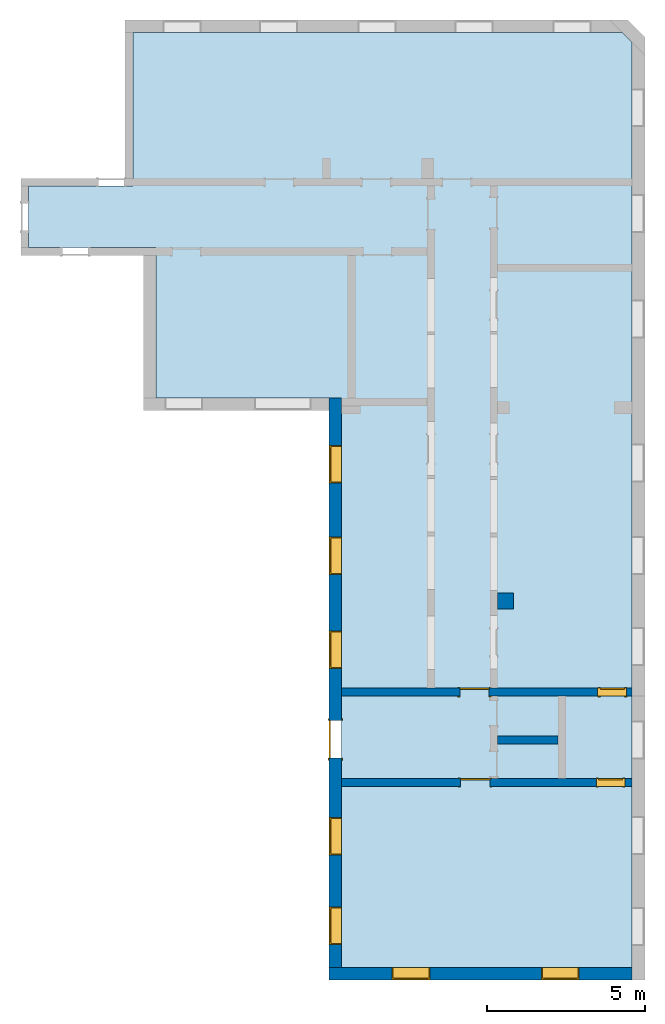
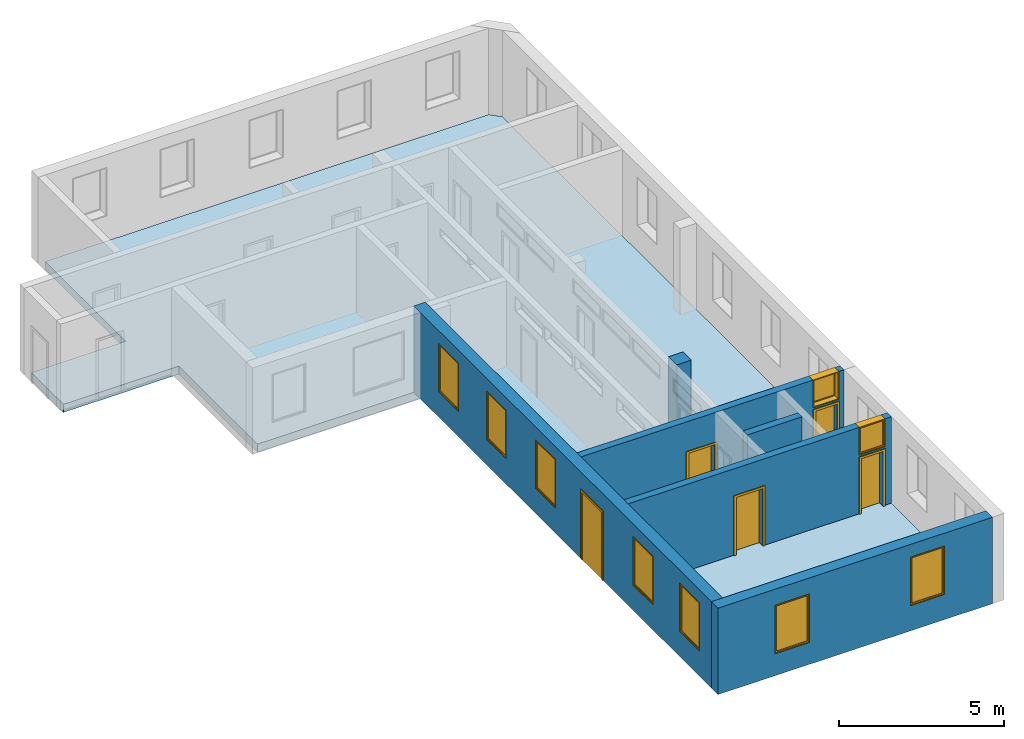
"""IFC2X3 building model written with IfcOpenShell, lengths in millimetres."""

from ifc_helpers import new_model, entity, si_unit, converted_unit, derived_unit, direction, frame, frame_2d, origin, origin_2d_with_axis, place, context, subcontext, project, spatial, polyline, rectangle, outline, extrude, source, transform, mapped, material, material_list, layer, layer_set, layer_usage, type_object, type_shapes, element, fill, save


model = new_model("IFC2X3")

# Units and contexts
model_context = context("Model", 3, precision=0.01, world=origin(), true_north=direction((6.12303176911189e-17, 1.0)))
context_of_model = context(None, 3, precision=0.01, world=origin(), true_north=direction((6.12303176911189e-17, 1.0)))
body_context = subcontext(model_context, "Body", "Model", "MODEL_VIEW")
ifc_project = project(units=[si_unit("LENGTHUNIT", "METRE", prefix="MILLI"), si_unit("AREAUNIT", "SQUARE_METRE"), si_unit("VOLUMEUNIT", "CUBIC_METRE"), converted_unit("PLANEANGLEUNIT", "DEGREE", entity("IfcRatioMeasure", 0.0174532925199433), si_unit("PLANEANGLEUNIT", "RADIAN"), dimensions=[0, 0, 0, 0, 0, 0, 0]), si_unit("MASSUNIT", "GRAM", prefix="KILO"), si_unit("TIMEUNIT", "SECOND"), si_unit("FREQUENCYUNIT", "HERTZ"), si_unit("THERMODYNAMICTEMPERATUREUNIT", "DEGREE_CELSIUS"), derived_unit("THERMALTRANSMITTANCEUNIT", [(si_unit("MASSUNIT", "GRAM", prefix="KILO"), 1), (si_unit("THERMODYNAMICTEMPERATUREUNIT", "KELVIN"), -1), (si_unit("TIMEUNIT", "SECOND"), -3)]), derived_unit("VOLUMETRICFLOWRATEUNIT", [(si_unit("LENGTHUNIT", "METRE"), 3), (si_unit("TIMEUNIT", "SECOND"), -1)]), si_unit("ELECTRICCURRENTUNIT", "AMPERE"), si_unit("ELECTRICVOLTAGEUNIT", "VOLT"), si_unit("POWERUNIT", "WATT"), si_unit("FORCEUNIT", "NEWTON", prefix="KILO"), si_unit("ILLUMINANCEUNIT", "LUX"), si_unit("LUMINOUSFLUXUNIT", "LUMEN"), si_unit("LUMINOUSINTENSITYUNIT", "CANDELA"), si_unit("PRESSUREUNIT", "PASCAL")], contexts=[model_context, context_of_model])

# Site, building, storey
site_placement = place(None, origin())
site = spatial("IfcSite", under=ifc_project, at=site_placement, CompositionType="ELEMENT")
building_placement = place(site_placement, origin())
building = spatial("IfcBuilding", under=site, at=building_placement, CompositionType="ELEMENT")
storey_1_placement = place(building_placement, origin())
storey_1 = spatial("IfcBuildingStorey", under=building, at=storey_1_placement, Name="i Plan", CompositionType="ELEMENT", Elevation=-5.41433564649196e-13)

# Slab
ifc_material_1 = material(Name="Default Floor")
ifc_layer_1 = layer(ifc_material_1, 300.0)
ifc_layer_set_1 = layer_set([ifc_layer_1], Name="Floor:Generic 300mm")
ifc_layer_usage_1 = layer_usage(ifc_layer_set_1, "AXIS3", "POSITIVE", 0.0)
slab_placement = place(storey_1_placement, origin())
element("IfcSlab", 1, at=slab_placement, inside=storey_1, material=ifc_layer_usage_1, Name="Floor:Generic 300mm", ObjectType="Floor:Generic 300mm", PredefinedType="FLOOR", context=body_context, shape_type="SweptSolid", body=[
    extrude(outline(polyline([(2827.55145361487, -8327.16929691403), (4776.72462534005, -8327.16929691403), (4776.72462534005, -5027.66312908422), (9646.31107922707, -5027.66312908421), (9646.31107922703, 10500.4665578726), (9343.94693401368, 10802.830703086), (-19985.4923423081, 10802.830703086), (-19985.4923423081, 1589.20257319905), (-1937.06828288073, 1589.20257319903), (-1937.06828288071, -4287.4341292231), (2827.55145361486, -4287.4341292231), (2827.55145361487, -8327.16929691403)])), frame((-5700.79066597761, 4570.08411792073, 0.0), z_axis=(0.0, 0.0, -1.0), x_axis=(0.0, 1.0, 0.0)), (0.0, 0.0, 1.0), 300.0),
])

# Wall, openings
ifc_material_2 = material(Name="Brick, Common")
ifc_layer_2 = layer(ifc_material_2, 400.0)
ifc_layer_set_2 = layer_set([ifc_layer_2], Name="Basic Wall:400mm")
ifc_layer_usage_2 = layer_usage(ifc_layer_set_2, "AXIS2", "NEGATIVE", 200.0)
wall_type_1 = type_object("IfcWallType", Name="Basic Wall:400mm", PredefinedType="STANDARD", material=ifc_layer_set_2)
wall_1_placement = place(storey_1_placement, frame((5102.04003710832, -15615.4082243874, 0.0), z_axis=(0.0, 0.0, 1.0), x_axis=(-1.0, 0.0, 0.0)))
wall_1 = element("IfcWallStandardCase", 2, at=wall_1_placement, inside=storey_1, type_object=wall_type_1, material=ifc_layer_usage_2, Name="Basic Wall:400mm", ObjectType="Basic Wall:400mm", context=body_context, shape_type="SweptSolid", body=[
    extrude(rectangle(XDim=9613.62812988691, YDim=400.0, at=frame_2d((4806.81406494345, 5.11590769747272e-13), x_axis=(-1.0, 0.0))), origin(), (0.0, 0.0, 1.0), 3199.99999999984),
])
opening_1_placement = place(wall_1_placement, frame((1680.0, -200.0, 930.0)))
opening_1 = element("IfcOpeningElement", 3, at=opening_1_placement, cuts=wall_1, Name="M_Fixed:72_1", ObjectType="Opening", context=body_context, shape_type="SweptSolid", body=[
    extrude(rectangle(XDim=1800.0, YDim=1200.0, at=frame_2d((899.999999999998, 600.0), x_axis=(1.0, 0.0))), frame((0.0, 0.0, 0.0), z_axis=(0.0, 1.0, 0.0), x_axis=(0.0, 0.0, 1.0)), (0.0, 0.0, 1.0), 400.0),
])
opening_2_placement = place(wall_1_placement, frame((6413.6281298869, -200.0, 810.0)))
opening_2 = element("IfcOpeningElement", 4, at=opening_2_placement, cuts=wall_1, Name="M_Fixed:72_1", ObjectType="Opening", context=body_context, shape_type="SweptSolid", body=[
    extrude(rectangle(XDim=1800.0, YDim=1200.0, at=frame_2d((899.999999999998, 600.0), x_axis=(1.0, 0.0))), frame((0.0, 0.0, 0.0), z_axis=(0.0, 1.0, 0.0), x_axis=(0.0, 0.0, 1.0)), (0.0, 0.0, 1.0), 400.0),
])

# Storey
storey_2_placement = place(building_placement, frame((0.0, 0.0, 960.0)))
storey_2 = spatial("IfcBuildingStorey", under=building, at=storey_2_placement, Name="Bottom windows", CompositionType="ELEMENT", Elevation=959.999999999999)

# Window
ifc_material_3 = material(Name="Glass")
ifc_material_4 = material(Name="Sash")
ifc_material_list_1 = material_list([ifc_material_3, ifc_material_4])
ifc_material_list_2 = material_list([ifc_material_3, ifc_material_4])
window_style_1 = type_object("IfcWindowStyle", Name="72", ConstructionType="NOTDEFINED", OperationType="NOTDEFINED", ParameterTakesPrecedence=False, Sizeable=False, material=ifc_material_list_2)
shared_shape_1 = source(origin(), body_context, "Body", "SweptSolid", [
    extrude(rectangle(XDim=12.0, YDim=1074.0, at=origin_2d_with_axis()), frame((600.0, 359.0, 63.0), z_axis=(0.0, 0.0, 1.0), x_axis=(0.0, -1.0, 0.0)), (0.0, 0.0, 1.0), 1674.0),
    extrude(outline(polyline([(-581.0, -881.0), (581.0, -881.0), (581.0, 881.0), (-581.0, 881.0), (-581.0, -881.0)]), holes=[polyline([(-537.0, -837.0), (-537.0, 837.0), (537.0, 837.0), (537.0, -837.0), (-537.0, -837.0)])]), frame((600.0, 337.0, 900.0), z_axis=(0.0, 1.0, 0.0), x_axis=(1.0, 0.0, 0.0)), (0.0, 0.0, 1.0), 44.0000000000274),
    extrude(outline(polyline([(-600.0, -900.0), (600.0, -900.0), (600.0, 900.0), (-600.0, 900.0), (-600.0, -900.0)]), holes=[polyline([(-581.0, -881.0), (-581.0, 881.0), (581.0, 881.0), (581.0, -881.0), (-581.0, -881.0)])]), frame((600.0, 337.0, 900.0), z_axis=(0.0, 1.0, 0.0), x_axis=(1.0, 0.0, 0.0)), (0.0, 0.0, 1.0), 63.0000000000275),
    extrude(outline(polyline([(-600.0, -900.0), (600.0, -900.0), (600.0, 900.0), (-600.0, 900.0), (-600.0, -900.0)]), holes=[polyline([(-568.0, -868.0), (-568.0, 868.0), (568.0, 868.0), (568.0, -868.0), (-568.0, -868.0)])]), frame((600.0, 0.0, 900.0), z_axis=(0.0, 1.0, 0.0), x_axis=(1.0, 0.0, 0.0)), (0.0, 0.0, 1.0), 336.999999999973),
])
type_shapes(window_style_1, [shared_shape_1])
window_1_placement = place(opening_1_placement, origin())
window_1 = element("IfcWindow", 5, at=window_1_placement, inside=storey_2, type_object=window_style_1, material=ifc_material_list_1, Name="M_Fixed:72", ObjectType="72", OverallHeight=1800.0, OverallWidth=1200.0, context=body_context, shape_type="MappedRepresentation", body=[
    mapped(shared_shape_1, transform((0.0, 0.0, 0.0), scale=1.0)),
])

fill(opening_1, window_1)

ifc_material_list_3 = material_list([ifc_material_3, ifc_material_4])
window_2_placement = place(opening_2_placement, origin())
window_2 = element("IfcWindow", 6, at=window_2_placement, inside=storey_1, type_object=window_style_1, material=ifc_material_list_3, Name="M_Fixed:72", ObjectType="72", OverallHeight=1800.0, OverallWidth=1200.0, context=body_context, shape_type="MappedRepresentation", body=[
    mapped(shared_shape_1, transform((0.0, 0.0, 0.0), scale=1.0)),
])

fill(opening_2, window_2)

# Wall, openings, windows, door
ifc_layer_usage_3 = layer_usage(ifc_layer_set_2, "AXIS2", "NEGATIVE", 200.0)
wall_2_placement = place(storey_1_placement, frame((-4311.58809277858, -15415.4082243873, 0.0), z_axis=(0.0, 0.0, 1.0), x_axis=(0.0, 1.0, 0.0)))
wall_2 = element("IfcWallStandardCase", 7, at=wall_2_placement, inside=storey_1, type_object=wall_type_1, material=ifc_layer_usage_3, Name="Basic Wall:400mm", ObjectType="Basic Wall:400mm", context=body_context, shape_type="SweptSolid", body=[
    extrude(rectangle(XDim=18048.4240594273, YDim=400.0, at=frame_2d((9024.21202971367, 0.0), x_axis=(-1.0, 0.0))), origin(), (0.0, 0.0, 1.0), 3199.99999999984),
])
opening_3_placement = place(wall_2_placement, frame((6631.21794312934, -200.0, 0.0)))
opening_3 = element("IfcOpeningElement", 8, at=opening_3_placement, cuts=wall_2, Name="M_Single-Flush:Great Door:1", ObjectType="Opening", context=body_context, shape_type="SweptSolid", body=[
    extrude(rectangle(XDim=1190.0, YDim=2500.0, at=frame_2d((1250.0, 595.0), x_axis=(0.0, -1.0))), frame((0.0, 0.0, 0.0), z_axis=(0.0, 1.0, 0.0), x_axis=(0.0, 0.0, 1.0)), (0.0, 0.0, 1.0), 400.0),
])
opening_4_placement = place(wall_2_placement, frame((15348.4240594273, -200.0, 930.0)))
opening_4 = element("IfcOpeningElement", 9, at=opening_4_placement, cuts=wall_2, Name="M_Fixed:72_1", ObjectType="Opening", context=body_context, shape_type="SweptSolid", body=[
    extrude(rectangle(XDim=1800.0, YDim=1200.0, at=frame_2d((899.999999999998, 600.0), x_axis=(1.0, 0.0))), frame((0.0, 0.0, 0.0), z_axis=(0.0, 1.0, 0.0), x_axis=(0.0, 0.0, 1.0)), (0.0, 0.0, 1.0), 400.0),
])
opening_5_placement = place(wall_2_placement, frame((12448.4240594273, -200.0, 930.0)))
opening_5 = element("IfcOpeningElement", 10, at=opening_5_placement, cuts=wall_2, Name="M_Fixed:72_1", ObjectType="Opening", context=body_context, shape_type="SweptSolid", body=[
    extrude(rectangle(XDim=1800.0, YDim=1200.0, at=frame_2d((899.999999999998, 600.0), x_axis=(1.0, 0.0))), frame((0.0, 0.0, 0.0), z_axis=(0.0, 1.0, 0.0), x_axis=(0.0, 0.0, 1.0)), (0.0, 0.0, 1.0), 400.0),
])
opening_6_placement = place(wall_2_placement, frame((9468.42405942734, -200.0, 930.0)))
opening_6 = element("IfcOpeningElement", 11, at=opening_6_placement, cuts=wall_2, Name="M_Fixed:72_1", ObjectType="Opening", context=body_context, shape_type="SweptSolid", body=[
    extrude(rectangle(XDim=1800.0, YDim=1200.0, at=frame_2d((899.999999999998, 600.0), x_axis=(1.0, 0.0))), frame((0.0, 0.0, 0.0), z_axis=(0.0, 1.0, 0.0), x_axis=(0.0, 0.0, 1.0)), (0.0, 0.0, 1.0), 400.0),
])
opening_7_placement = place(wall_2_placement, frame((3556.21794312935, -200.0, 930.0)))
opening_7 = element("IfcOpeningElement", 12, at=opening_7_placement, cuts=wall_2, Name="M_Fixed:72_1", ObjectType="Opening", context=body_context, shape_type="SweptSolid", body=[
    extrude(rectangle(XDim=1800.0, YDim=1200.0, at=frame_2d((899.999999999998, 600.0), x_axis=(1.0, 0.0))), frame((0.0, 0.0, 0.0), z_axis=(0.0, 1.0, 0.0), x_axis=(0.0, 0.0, 1.0)), (0.0, 0.0, 1.0), 400.0),
])
opening_8_placement = place(wall_2_placement, frame((720.0, -200.0, 930.0)))
opening_8 = element("IfcOpeningElement", 13, at=opening_8_placement, cuts=wall_2, Name="M_Fixed:72_1", ObjectType="Opening", context=body_context, shape_type="SweptSolid", body=[
    extrude(rectangle(XDim=1800.0, YDim=1200.0, at=frame_2d((899.999999999998, 600.0), x_axis=(1.0, 0.0))), frame((0.0, 0.0, 0.0), z_axis=(0.0, 1.0, 0.0), x_axis=(0.0, 0.0, 1.0)), (0.0, 0.0, 1.0), 400.0),
])
ifc_material_list_4 = material_list([ifc_material_3, ifc_material_4])
window_3_placement = place(opening_4_placement, origin())
window_3 = element("IfcWindow", 14, at=window_3_placement, inside=storey_2, type_object=window_style_1, material=ifc_material_list_4, Name="M_Fixed:72", ObjectType="72", OverallHeight=1800.0, OverallWidth=1200.0, context=body_context, shape_type="MappedRepresentation", body=[
    mapped(shared_shape_1, transform((0.0, 0.0, 0.0), scale=1.0)),
])
fill(opening_4, window_3)
ifc_material_list_5 = material_list([ifc_material_3, ifc_material_4])
window_4_placement = place(opening_5_placement, origin())
window_4 = element("IfcWindow", 15, at=window_4_placement, inside=storey_2, type_object=window_style_1, material=ifc_material_list_5, Name="M_Fixed:72", ObjectType="72", OverallHeight=1800.0, OverallWidth=1200.0, context=body_context, shape_type="MappedRepresentation", body=[
    mapped(shared_shape_1, transform((0.0, 0.0, 0.0), scale=1.0)),
])
fill(opening_5, window_4)
ifc_material_list_6 = material_list([ifc_material_3, ifc_material_4])
window_5_placement = place(opening_6_placement, origin())
window_5 = element("IfcWindow", 16, at=window_5_placement, inside=storey_2, type_object=window_style_1, material=ifc_material_list_6, Name="M_Fixed:72", ObjectType="72", OverallHeight=1800.0, OverallWidth=1200.0, context=body_context, shape_type="MappedRepresentation", body=[
    mapped(shared_shape_1, transform((0.0, 0.0, 0.0), scale=1.0)),
])
fill(opening_6, window_5)
ifc_material_list_7 = material_list([ifc_material_3, ifc_material_4])
window_6_placement = place(opening_7_placement, origin())
window_6 = element("IfcWindow", 17, at=window_6_placement, inside=storey_2, type_object=window_style_1, material=ifc_material_list_7, Name="M_Fixed:72", ObjectType="72", OverallHeight=1800.0, OverallWidth=1200.0, context=body_context, shape_type="MappedRepresentation", body=[
    mapped(shared_shape_1, transform((0.0, 0.0, 0.0), scale=1.0)),
])
fill(opening_7, window_6)
ifc_material_list_8 = material_list([ifc_material_3, ifc_material_4])
window_7_placement = place(opening_8_placement, origin())
window_7 = element("IfcWindow", 18, at=window_7_placement, inside=storey_2, type_object=window_style_1, material=ifc_material_list_8, Name="M_Fixed:72", ObjectType="72", OverallHeight=1800.0, OverallWidth=1200.0, context=body_context, shape_type="MappedRepresentation", body=[
    mapped(shared_shape_1, transform((0.0, 0.0, 0.0), scale=1.0)),
])
fill(opening_8, window_7)
ifc_material_5 = material(Name="Door - Frame")
ifc_material_6 = material(Name="Door - Panel")
ifc_material_list_9 = material_list([ifc_material_5, ifc_material_6])
ifc_material_list_10 = material_list([ifc_material_5, ifc_material_6])
door_style_1 = type_object("IfcDoorStyle", Name="Great Door", ConstructionType="NOTDEFINED", OperationType="SINGLE_SWING_LEFT", ParameterTakesPrecedence=False, Sizeable=False, material=ifc_material_list_10)
shared_shape_2 = source(origin(), body_context, "Body", "SweptSolid", [
    extrude(outline(polyline([(-671.0, -1307.0), (671.0, -1307.0), (671.0, 1269.0), (595.0, 1269.0), (595.0, -1231.0), (-595.0, -1231.0), (-595.0, 1269.0), (-671.0, 1269.0), (-671.0, -1307.0)])), frame((595.0, 425.0, 1269.0), z_axis=(0.0, -1.0, 0.0), x_axis=(-1.0, 0.0, 0.0)), (0.0, 0.0, 1.0), 24.9999999999945),
    extrude(outline(polyline([(-1307.0, -671.0), (1269.0, -671.0), (1269.0, -595.0), (-1231.0, -595.0), (-1231.0, 595.0), (1269.0, 595.0), (1269.0, 671.0), (-1307.0, 671.0), (-1307.0, -671.0)])), frame((595.0, 0.0, 1269.0), z_axis=(0.0, -1.0, 0.0), x_axis=(0.0, 0.0, -1.0)), (0.0, 0.0, 1.0), 25.0000000000056),
    extrude(rectangle(XDim=1190.0, YDim=51.0, at=frame_2d((0.0, 1.77635683940025e-14), x_axis=(1.0, 0.0))), frame((595.0, 374.499999999994, 0.0)), (0.0, 0.0, 1.0), 2500.0),
])
type_shapes(door_style_1, [shared_shape_2])
door_1_placement = place(opening_3_placement, origin())
door_1 = element("IfcDoor", 19, at=door_1_placement, inside=storey_1, type_object=door_style_1, material=ifc_material_list_9, Name="M_Single-Flush:Great Door", ObjectType="Great Door", OverallHeight=2500.0, OverallWidth=1190.0, context=body_context, shape_type="MappedRepresentation", body=[
    mapped(shared_shape_2, transform((0.0, 0.0, 0.0), scale=1.0)),
])
fill(opening_3, door_1)

# Wall, openings, doors, window
ifc_material_7 = material(Name="Default Wall")
ifc_layer_3 = layer(ifc_material_7, 250.0)
ifc_layer_set_3 = layer_set([ifc_layer_3], Name="Basic Wall:250 mm")
ifc_layer_usage_4 = layer_usage(ifc_layer_set_3, "AXIS2", "NEGATIVE", 125.0)
wall_type_2 = type_object("IfcWallType", Name="Basic Wall:250 mm", PredefinedType="STANDARD", material=ifc_layer_set_3)
wall_3_placement = place(storey_1_placement, frame((5102.04003710834, -6688.09629601622, 0.0), z_axis=(0.0, 0.0, 1.0), x_axis=(-1.0, 0.0, 0.0)))
wall_3 = element("IfcWallStandardCase", 20, at=wall_3_placement, inside=storey_1, type_object=wall_type_2, material=ifc_layer_usage_4, Name="Basic Wall:250 mm", ObjectType="Basic Wall:250 mm", context=body_context, shape_type="SweptSolid", body=[
    extrude(rectangle(XDim=9213.62812988691, YDim=249.999999999999, at=frame_2d((4606.81406494345, -2.77111666946439e-13), x_axis=(-1.0, 0.0))), origin(), (0.0, 0.0, 1.0), 3200.0),
])
opening_9_placement = place(wall_3_placement, frame((5453.6281298869, 125.0, 0.0)))
opening_9 = element("IfcOpeningElement", 21, at=opening_9_placement, cuts=wall_3, Name="M_Single-Flush:0915 x 2032mm:1", ObjectType="Opening", context=body_context, shape_type="SweptSolid", body=[
    extrude(rectangle(XDim=915.0, YDim=2032.0, at=frame_2d((1016.0, 457.5), x_axis=(0.0, 1.0))), frame((0.0, 0.0, 0.0), z_axis=(0.0, -1.0, 0.0), x_axis=(0.0, 0.0, 1.0)), (0.0, 0.0, 1.0), 250.0),
])
opening_10_placement = place(wall_3_placement, frame((1007.0, 125.0, 0.0)))
opening_10 = element("IfcOpeningElement", 22, at=opening_10_placement, cuts=wall_3, Name="M_Single-Flush:0762 x 2032mm:1", ObjectType="Opening", context=body_context, shape_type="SweptSolid", body=[
    extrude(rectangle(XDim=762.0, YDim=2032.0, at=frame_2d((1016.0, 381.0), x_axis=(0.0, 1.0))), frame((0.0, 0.0, 0.0), z_axis=(0.0, -1.0, 0.0), x_axis=(0.0, 0.0, 1.0)), (0.0, 0.0, 1.0), 250.0),
])
opening_11_placement = place(wall_3_placement, frame((1094.0, 125.0, 2172.0)))
opening_11 = element("IfcOpeningElement", 23, at=opening_11_placement, cuts=wall_3, Name="M_Fixed:762:1", ObjectType="Opening", context=body_context, shape_type="SweptSolid", body=[
    extrude(rectangle(XDim=1028.0, YDim=914.0, at=frame_2d((513.999999999999, 457.0), x_axis=(1.0, 0.0))), frame((0.0, 0.0, 0.0), z_axis=(0.0, -1.0, 0.0), x_axis=(0.0, 0.0, 1.0)), (0.0, 0.0, 1.0), 250.0),
])
ifc_material_list_11 = material_list([ifc_material_5, ifc_material_6])
ifc_material_list_12 = material_list([ifc_material_5, ifc_material_6])
door_style_2 = type_object("IfcDoorStyle", Name="0762 x 2032mm", ConstructionType="NOTDEFINED", OperationType="SINGLE_SWING_RIGHT", ParameterTakesPrecedence=False, Sizeable=False, material=ifc_material_list_12)
shared_shape_3 = source(origin(), body_context, "Body", "SweptSolid", [
    extrude(outline(polyline([(-457.0, -1073.0), (457.0, -1073.0), (457.0, 1035.0), (381.0, 1035.0), (381.0, -997.0), (-381.0, -997.0), (-381.0, 1035.0), (-457.0, 1035.0), (-457.0, -1073.0)])), frame((381.0, 250.0, 1035.0), z_axis=(0.0, 1.0, 0.0), x_axis=(1.0, 0.0, 0.0)), (0.0, 0.0, 1.0), 24.9999999999945),
    extrude(outline(polyline([(-1073.0, -457.0), (1035.0, -457.0), (1035.0, -381.0), (-997.0, -381.0), (-997.0, 381.0), (1035.0, 381.0), (1035.0, 457.0), (-1073.0, 457.0), (-1073.0, -457.0)])), frame((381.0, -25.0, 1035.0), z_axis=(0.0, 1.0, 0.0), x_axis=(0.0, 0.0, -1.0)), (0.0, 0.0, 1.0), 25.0000000000056),
    extrude(rectangle(XDim=51.0, YDim=762.0, at=frame_2d((5.32907051820075e-15, 0.0), x_axis=(1.0, 0.0))), frame((381.0, 224.499999999999, 0.0), z_axis=(0.0, 0.0, 1.0), x_axis=(0.0, 1.0, 0.0)), (0.0, 0.0, 1.0), 2032.0),
])
type_shapes(door_style_2, [shared_shape_3])
door_2_placement = place(opening_10_placement, frame((0.0, 0.0, 0.0), z_axis=(0.0, 0.0, 1.0), x_axis=(-1.0, 0.0, 0.0)))
door_2 = element("IfcDoor", 24, at=door_2_placement, inside=storey_1, type_object=door_style_2, material=ifc_material_list_11, Name="M_Single-Flush:0762 x 2032mm", ObjectType="0762 x 2032mm", OverallHeight=2032.0, OverallWidth=762.0, context=body_context, shape_type="MappedRepresentation", body=[
    mapped(shared_shape_3, transform((0.0, 0.0, 0.0), scale=1.0)),
])
fill(opening_10, door_2)
ifc_material_list_13 = material_list([ifc_material_5, ifc_material_6])
ifc_material_list_14 = material_list([ifc_material_5, ifc_material_6])
door_style_3 = type_object("IfcDoorStyle", Name="0915 x 2032mm", ConstructionType="NOTDEFINED", OperationType="SINGLE_SWING_RIGHT", ParameterTakesPrecedence=False, Sizeable=False, material=ifc_material_list_14)
shared_shape_4 = source(origin(), body_context, "Body", "SweptSolid", [
    extrude(outline(polyline([(-533.5, -1073.0), (533.5, -1073.0), (533.5, 1035.0), (457.5, 1035.0), (457.5, -997.0), (-457.5, -997.0), (-457.5, 1035.0), (-533.5, 1035.0), (-533.5, -1073.0)])), frame((457.5, 250.0, 1035.0), z_axis=(0.0, 1.0, 0.0), x_axis=(1.0, 0.0, 0.0)), (0.0, 0.0, 1.0), 24.9999999999945),
    extrude(outline(polyline([(-1073.0, -533.499999999997), (1035.0, -533.499999999997), (1035.0, -457.500000000007), (-997.0, -457.500000000007), (-997.0, 457.500000000002), (1035.0, 457.500000000002), (1035.0, 533.500000000003), (-1073.0, 533.500000000003), (-1073.0, -533.499999999997)])), frame((457.500000000003, -25.0, 1035.0), z_axis=(0.0, 1.0, 0.0), x_axis=(0.0, 0.0, -1.0)), (0.0, 0.0, 1.0), 25.0000000000056),
    extrude(rectangle(XDim=51.0, YDim=915.0, at=frame_2d((5.32907051820075e-15, 0.0), x_axis=(1.0, 0.0))), frame((457.5, 224.500000000001, 0.0), z_axis=(0.0, 0.0, 1.0), x_axis=(0.0, 1.0, 0.0)), (0.0, 0.0, 1.0), 2032.0),
])
type_shapes(door_style_3, [shared_shape_4])
door_3_placement = place(opening_9_placement, frame((0.0, 0.0, 0.0), z_axis=(0.0, 0.0, 1.0), x_axis=(-1.0, 0.0, 0.0)))
door_3 = element("IfcDoor", 25, at=door_3_placement, inside=storey_1, type_object=door_style_3, material=ifc_material_list_13, Name="M_Single-Flush:0915 x 2032mm", ObjectType="0915 x 2032mm", OverallHeight=2032.0, OverallWidth=915.0, context=body_context, shape_type="MappedRepresentation", body=[
    mapped(shared_shape_4, transform((0.0, 0.0, 0.0), scale=1.0)),
])
fill(opening_9, door_3)
ifc_material_list_15 = material_list([ifc_material_3, ifc_material_4])
ifc_material_list_16 = material_list([ifc_material_3, ifc_material_4])
window_style_2 = type_object("IfcWindowStyle", Name="762", ConstructionType="NOTDEFINED", OperationType="NOTDEFINED", ParameterTakesPrecedence=False, Sizeable=False, material=ifc_material_list_16)
shared_shape_5 = source(origin(), body_context, "Body", "SweptSolid", [
    extrude(rectangle(XDim=12.0, YDim=787.999999999997, at=frame_2d((-8.43769498715119e-15, 0.0), x_axis=(1.0, 0.0))), frame((457.0, 209.0, 63.0), z_axis=(0.0, 0.0, 1.0), x_axis=(0.0, -1.0, 0.0)), (0.0, 0.0, 1.0), 902.000000000008),
    extrude(outline(polyline([(-438.0, -495.0), (438.0, -495.0), (438.0, 495.0), (-438.0, 495.0), (-438.0, -495.0)]), holes=[polyline([(-394.0, -451.0), (-394.0, 451.0), (394.0, 451.0), (394.0, -451.0), (-394.0, -451.0)])]), frame((457.0, 187.0, 514.0), z_axis=(0.0, 1.0, 0.0), x_axis=(1.0, 0.0, 0.0)), (0.0, 0.0, 1.0), 44.0000000000274),
    extrude(outline(polyline([(-457.0, -514.0), (457.0, -514.0), (457.0, 514.0), (-457.0, 514.0), (-457.0, -514.0)]), holes=[polyline([(-438.0, -495.0), (-438.0, 495.0), (438.0, 495.0), (438.0, -495.0), (-438.0, -495.0)])]), frame((457.0, 187.0, 514.0), z_axis=(0.0, 1.0, 0.0), x_axis=(1.0, 0.0, 0.0)), (0.0, 0.0, 1.0), 63.0000000000274),
    extrude(outline(polyline([(-457.0, -514.0), (457.0, -514.0), (457.0, 514.0), (-457.0, 514.0), (-457.0, -514.0)]), holes=[polyline([(-425.0, -482.0), (-425.0, 482.0), (425.0, 482.0), (425.0, -482.0), (-425.0, -482.0)])]), frame((457.0, 0.0, 514.0), z_axis=(0.0, 1.0, 0.0), x_axis=(1.0, 0.0, 0.0)), (0.0, 0.0, 1.0), 186.999999999973),
])
type_shapes(window_style_2, [shared_shape_5])
window_8_placement = place(opening_11_placement, frame((0.0, 0.0, 0.0), z_axis=(0.0, 0.0, 1.0), x_axis=(-1.0, 0.0, 0.0)))
window_8 = element("IfcWindow", 26, at=window_8_placement, inside=storey_2, type_object=window_style_2, material=ifc_material_list_15, Name="M_Fixed:762", ObjectType="762", OverallHeight=1028.0, OverallWidth=914.0, context=body_context, shape_type="MappedRepresentation", body=[
    mapped(shared_shape_5, transform((0.0, 0.0, 0.0), scale=1.0)),
])
fill(opening_11, window_8)

ifc_layer_usage_5 = layer_usage(ifc_layer_set_3, "AXIS2", "NEGATIVE", 125.0)
wall_4_placement = place(storey_1_placement, frame((-4111.58809277857, -9554.19028125798, 0.0)))
wall_4 = element("IfcWallStandardCase", 27, at=wall_4_placement, inside=storey_1, type_object=wall_type_2, material=ifc_layer_usage_5, Name="Basic Wall:250 mm", ObjectType="Basic Wall:250 mm", context=body_context, shape_type="SweptSolid", body=[
    extrude(rectangle(XDim=9213.62812988691, YDim=249.999999999999, at=frame_2d((4606.81406494345, 1.06581410364015e-13), x_axis=(-1.0, 0.0))), origin(), (0.0, 0.0, 1.0), 3200.1),
])
opening_12_placement = place(wall_4_placement, frame((3770.0, -125.0, 0.0)))
opening_12 = element("IfcOpeningElement", 28, at=opening_12_placement, cuts=wall_4, Name="M_Single-Flush:72 door wide:1", ObjectType="Opening", context=body_context, shape_type="SweptSolid", body=[
    extrude(rectangle(XDim=930.0, YDim=2134.0, at=frame_2d((1067.0, 465.0), x_axis=(0.0, 1.0))), frame((0.0, 0.0, 0.0), z_axis=(0.0, 1.0, 0.0), x_axis=(0.0, 0.0, 1.0)), (0.0, 0.0, 1.0), 250.0),
])
opening_13_placement = place(wall_4_placement, frame((8151.6281298869, -125.0, 0.0)))
opening_13 = element("IfcOpeningElement", 29, at=opening_13_placement, cuts=wall_4, Name="M_Single-Flush:0762 x 2032mm:1", ObjectType="Opening", context=body_context, shape_type="SweptSolid", body=[
    extrude(rectangle(XDim=762.0, YDim=2032.0, at=frame_2d((1016.0, 381.0), x_axis=(0.0, 1.0))), frame((0.0, 0.0, 0.0), z_axis=(0.0, 1.0, 0.0), x_axis=(0.0, 0.0, 1.0)), (0.0, 0.0, 1.0), 250.0),
])
opening_14_placement = place(wall_4_placement, frame((8993.62812988687, 125.0, 2172.1)))
opening_14 = element("IfcOpeningElement", 30, at=opening_14_placement, cuts=wall_4, Name="M_Fixed:762:1", ObjectType="Opening", context=body_context, shape_type="SweptSolid", body=[
    extrude(rectangle(XDim=1028.0, YDim=914.0, at=frame_2d((513.999999999999, 457.0), x_axis=(1.0, 0.0))), frame((0.0, 0.0, 0.0), z_axis=(0.0, -1.0, 0.0), x_axis=(0.0, 0.0, 1.0)), (0.0, 0.0, 1.0), 250.0),
])
ifc_material_list_17 = material_list([ifc_material_5, ifc_material_6])
ifc_material_list_18 = material_list([ifc_material_5, ifc_material_6])
door_style_4 = type_object("IfcDoorStyle", Name="72 door wide", ConstructionType="NOTDEFINED", OperationType="SINGLE_SWING_RIGHT", ParameterTakesPrecedence=False, Sizeable=False, material=ifc_material_list_18)
shared_shape_6 = source(origin(), body_context, "Body", "SweptSolid", [
    extrude(outline(polyline([(-541.0, -1124.0), (541.0, -1124.0), (541.0, 1086.0), (465.0, 1086.0), (465.0, -1048.0), (-465.0, -1048.0), (-465.0, 1086.0), (-541.0, 1086.0), (-541.0, -1124.0)])), frame((465.0, 250.0, 1086.0), z_axis=(0.0, 1.0, 0.0), x_axis=(1.0, 0.0, 0.0)), (0.0, 0.0, 1.0), 24.9999999999945),
    extrude(outline(polyline([(-1124.0, -541.0), (1086.0, -541.0), (1086.0, -465.0), (-1048.0, -465.0), (-1048.0, 465.0), (1086.0, 465.0), (1086.0, 541.0), (-1124.0, 541.0), (-1124.0, -541.0)])), frame((465.0, -25.0, 1086.0), z_axis=(0.0, 1.0, 0.0), x_axis=(0.0, 0.0, -1.0)), (0.0, 0.0, 1.0), 25.0000000000056),
    extrude(rectangle(XDim=51.0, YDim=930.0, at=frame_2d((5.32907051820075e-15, 0.0), x_axis=(1.0, 0.0))), frame((465.0, 224.499999999999, 0.0), z_axis=(0.0, 0.0, 1.0), x_axis=(0.0, 1.0, 0.0)), (0.0, 0.0, 1.0), 2134.0),
])
type_shapes(door_style_4, [shared_shape_6])
door_4_placement = place(opening_12_placement, origin())
door_4 = element("IfcDoor", 31, at=door_4_placement, inside=storey_1, type_object=door_style_4, material=ifc_material_list_17, Name="M_Single-Flush:72 door wide", ObjectType="72 door wide", OverallHeight=2134.0, OverallWidth=930.0, context=body_context, shape_type="MappedRepresentation", body=[
    mapped(shared_shape_6, transform((0.0, 0.0, 0.0), scale=1.0)),
])
fill(opening_12, door_4)
ifc_material_list_19 = material_list([ifc_material_5, ifc_material_6])
door_5_placement = place(opening_13_placement, origin())
door_5 = element("IfcDoor", 32, at=door_5_placement, inside=storey_1, type_object=door_style_2, material=ifc_material_list_19, Name="M_Single-Flush:0762 x 2032mm", ObjectType="0762 x 2032mm", OverallHeight=2032.0, OverallWidth=762.0, context=body_context, shape_type="MappedRepresentation", body=[
    mapped(shared_shape_3, transform((0.0, 0.0, 0.0), scale=1.0)),
])
fill(opening_13, door_5)
ifc_material_list_20 = material_list([ifc_material_3, ifc_material_4])
window_9_placement = place(opening_14_placement, frame((0.0, 0.0, 0.0), z_axis=(0.0, 0.0, 1.0), x_axis=(-1.0, 0.0, 0.0)))
window_9 = element("IfcWindow", 33, at=window_9_placement, inside=storey_2, type_object=window_style_2, material=ifc_material_list_20, Name="M_Fixed:762", ObjectType="762", OverallHeight=1028.0, OverallWidth=914.0, context=body_context, shape_type="MappedRepresentation", body=[
    mapped(shared_shape_5, transform((0.0, 0.0, 0.0), scale=1.0)),
])
fill(opening_14, window_9)

# Walls
ifc_layer_usage_6 = layer_usage(ifc_layer_set_3, "AXIS2", "NEGATIVE", 125.0)
wall_5_placement = place(storey_1_placement, frame((838.411907221432, -8204.190281258, 0.0)))
element("IfcWallStandardCase", 34, at=wall_5_placement, inside=storey_1, type_object=wall_type_2, material=ifc_layer_usage_6, Name="Basic Wall:250 mm", ObjectType="Basic Wall:250 mm", context=body_context, shape_type="SweptSolid", body=[
    extrude(rectangle(XDim=1913.6281298869, YDim=249.999999999999, at=frame_2d((956.81406494345, 7.105427357601e-14), x_axis=(-1.0, 0.0))), origin(), (0.0, 0.0, 1.0), 3199.99999999984),
])
ifc_layer_4 = layer(ifc_material_7, 500.0)
ifc_layer_set_4 = layer_set([ifc_layer_4], Name="Basic Wall:500mmk 3")
ifc_layer_usage_7 = layer_usage(ifc_layer_set_4, "AXIS2", "NEGATIVE", 250.0)
wall_type_3 = type_object("IfcWallType", Name="Basic Wall:500mmk 3", PredefinedType="STANDARD", material=ifc_layer_set_4)
wall_6_placement = place(storey_1_placement, frame((838.411907221439, -3803.19125673925, 0.0)))
element("IfcWallStandardCase", 35, at=wall_6_placement, inside=storey_1, type_object=wall_type_3, material=ifc_layer_usage_7, Name="Basic Wall:500mmk 3", ObjectType="Basic Wall:500mmk 3", context=body_context, shape_type="SweptSolid", body=[
    extrude(rectangle(XDim=504.235914481327, YDim=500.0, at=frame_2d((252.117957240664, 0.0), x_axis=(-1.0, 0.0))), origin(), (0.0, 0.0, 1.0), 3199.99999999984),
])

save(model, "model.ifc")
